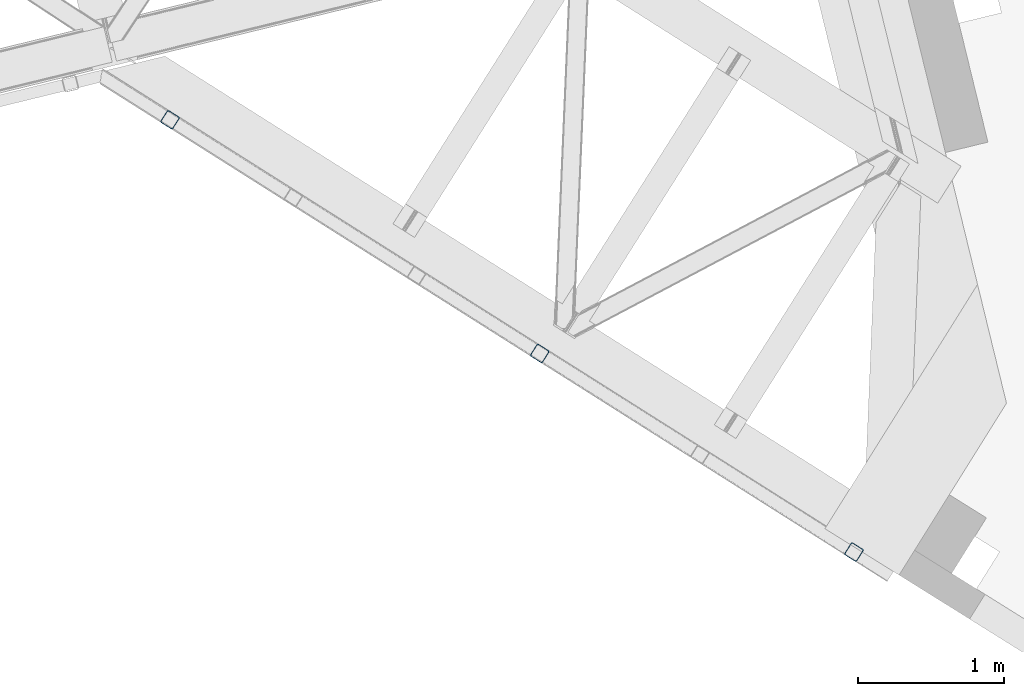
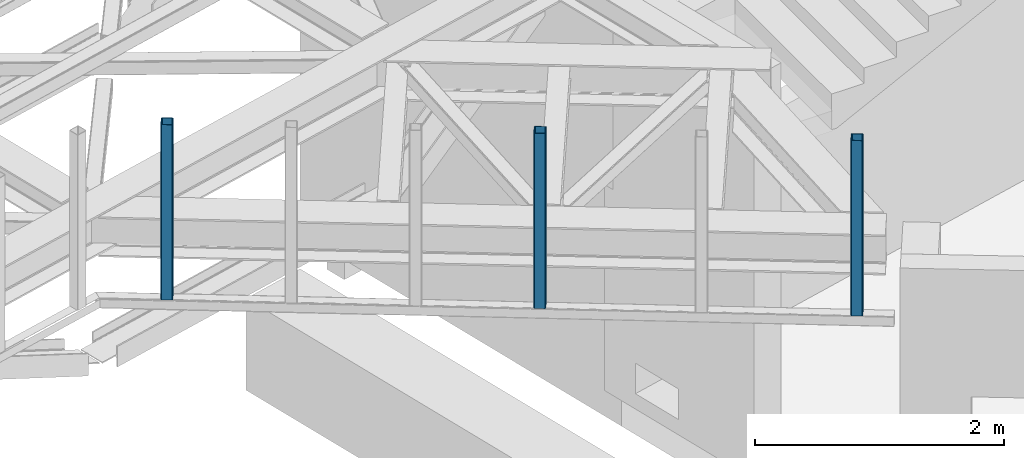
# One storey, part 9 of 66: 3 columns.
"""IFC4 building model written with IfcOpenShell, lengths in millimetres."""

from ifc_helpers import new_model, entity, si_unit, converted_unit, derived_unit, direction, frame, origin, place, context, subcontext, project, spatial, indexed_curve, outline, extrude, type_object, element, save


model = new_model("IFC4")

# Units and contexts
model_context = context("Model", 3, precision=0.01, world=origin(), true_north=direction((6.12303176911189e-17, 1.0)))
plan_context = context("Plan", 3, precision=0.01, world=origin(), true_north=direction((6.12303176911189e-17, 1.0)))
body_context = subcontext(model_context, "Body", "Model", "MODEL_VIEW")
ifc_project = project(units=[si_unit("LENGTHUNIT", "METRE", prefix="MILLI"), si_unit("AREAUNIT", "SQUARE_METRE"), si_unit("VOLUMEUNIT", "CUBIC_METRE"), converted_unit("PLANEANGLEUNIT", "DEGREE", entity("IfcRatioMeasure", 0.0174532925199433), si_unit("PLANEANGLEUNIT", "RADIAN"), dimensions=[0, 0, 0, 0, 0, 0, 0]), si_unit("MASSUNIT", "GRAM", prefix="KILO"), derived_unit("MASSDENSITYUNIT", [(si_unit("MASSUNIT", "GRAM", prefix="KILO"), 1), (si_unit("LENGTHUNIT", "METRE"), -3)]), derived_unit("MOMENTOFINERTIAUNIT", [(si_unit("LENGTHUNIT", "METRE"), 4)]), si_unit("TIMEUNIT", "SECOND"), si_unit("FREQUENCYUNIT", "HERTZ"), si_unit("THERMODYNAMICTEMPERATUREUNIT", "DEGREE_CELSIUS"), derived_unit("THERMALTRANSMITTANCEUNIT", [(si_unit("MASSUNIT", "GRAM", prefix="KILO"), 1), (si_unit("THERMODYNAMICTEMPERATUREUNIT", "KELVIN"), -1), (si_unit("TIMEUNIT", "SECOND"), -3)]), derived_unit("VOLUMETRICFLOWRATEUNIT", [(si_unit("LENGTHUNIT", "METRE"), 3), (si_unit("TIMEUNIT", "SECOND"), -1)]), derived_unit("MASSFLOWRATEUNIT", [(si_unit("MASSUNIT", "GRAM", prefix="KILO"), 1), (si_unit("TIMEUNIT", "SECOND"), -1)]), derived_unit("ROTATIONALFREQUENCYUNIT", [(si_unit("TIMEUNIT", "SECOND"), -1)]), si_unit("ELECTRICCURRENTUNIT", "AMPERE"), si_unit("ELECTRICVOLTAGEUNIT", "VOLT"), si_unit("POWERUNIT", "WATT"), si_unit("FORCEUNIT", "NEWTON", prefix="KILO"), si_unit("ILLUMINANCEUNIT", "LUX"), si_unit("LUMINOUSFLUXUNIT", "LUMEN"), si_unit("LUMINOUSINTENSITYUNIT", "CANDELA"), derived_unit("USERDEFINED", [(si_unit("MASSUNIT", "GRAM", prefix="KILO"), -1), (si_unit("LENGTHUNIT", "METRE"), -2), (si_unit("TIMEUNIT", "SECOND"), 3), (si_unit("LUMINOUSFLUXUNIT", "LUMEN"), 1)]), derived_unit("LINEARVELOCITYUNIT", [(si_unit("LENGTHUNIT", "METRE"), 1), (si_unit("TIMEUNIT", "SECOND"), -1)]), si_unit("PRESSUREUNIT", "PASCAL"), derived_unit("USERDEFINED", [(si_unit("LENGTHUNIT", "METRE"), -2), (si_unit("MASSUNIT", "GRAM", prefix="KILO"), 1), (si_unit("TIMEUNIT", "SECOND"), -2)]), derived_unit("LINEARFORCEUNIT", [(si_unit("MASSUNIT", "GRAM", prefix="KILO"), 1), (si_unit("LENGTHUNIT", "METRE"), 1), (si_unit("TIMEUNIT", "SECOND"), -2), (si_unit("LENGTHUNIT", "METRE"), -1)]), derived_unit("PLANARFORCEUNIT", [(si_unit("MASSUNIT", "GRAM", prefix="KILO"), 1), (si_unit("LENGTHUNIT", "METRE"), 1), (si_unit("TIMEUNIT", "SECOND"), -2), (si_unit("LENGTHUNIT", "METRE"), -2)])], contexts=[model_context, plan_context])

# Site, building, storey
site_placement = place(None, origin())
site = spatial("IfcSite", under=ifc_project, at=site_placement, CompositionType="ELEMENT")
building_placement = place(site_placement, origin())
building = spatial("IfcBuilding", under=site, at=building_placement, CompositionType="ELEMENT")
storey_placement = place(building_placement, frame((0.0, 0.0, 19800.0)))
storey = spatial("IfcBuildingStorey", under=building, at=storey_placement, Name="06", CompositionType="ELEMENT", Elevation=19800.0)

# Columns
column_type_1 = type_object("IfcColumnType", PredefinedType="COLUMN")
placement = place(storey_placement, origin())
element("IfcColumn", 1, at=placement, inside=storey, type_object=column_type_1, ObjectType="Steel Column", PredefinedType="COLUMN", context=body_context, shape_type="SweptSolid", body=[
    extrude(outline(indexed_curve([(29.4768951149887, -56.8428769007626), (33.3787015553205, -56.8428769007626), (36.9835006653681, -55.3497202197607), (39.7424944582164, -52.5907264269385), (41.2356511392555, -48.9859273169046), (56.8428769010712, 29.4768951152554), (56.842876901092, 33.3787015555708), (55.3497202201102, 36.9835006656042), (52.5907264272972, 39.7424944584316), (48.9859273172661, 41.2356511394393), (-29.4768951149897, 56.8428769007575), (-33.3787015553141, 56.8428769007627), (-36.9835006653618, 55.3497202197608), (-39.7424944582241, 52.5907264269286), (-41.2356511392497, 48.9859273169045), (-56.8428769010719, -29.4768951152604), (-56.8428769011011, -33.3787015555789), (-55.3497202201039, -36.983500665604), (-52.5907264272974, -39.7424944584386), (-48.9859273172602, -41.2356511394394), (29.4768951149887, -56.8428769007626)], self_intersect=False), holes=[indexed_curve([(-43.1065493051361, -37.3071763475209), (-46.711348415166, -35.8140196665104), (-49.4703422079919, -33.0550258736856), (-50.9634988889722, -29.4502267636517), (-50.9634988889409, -25.5484203233276), (-37.307176347356, 43.1065493048057), (-35.8140196663157, 46.7113484148424), (-33.0550258734699, 49.4703422076636), (-29.4502267634194, 50.9634988886596), (-25.5484203231011, 50.9634988886614), (43.1065493051387, 37.3071763475173), (46.7113484151633, 35.8140196665024), (49.4703422079667, 33.0550258736713), (50.9634988889637, 29.4502267636392), (50.9634988889363, 25.5484203233305), (37.3071763473442, -43.1065493048172), (35.8140196663094, -46.7113484148471), (33.0550258734735, -49.4703422076669), (29.4502267634084, -50.9634988886731), (25.5484203230805, -50.963498888674), (-43.1065493051361, -37.3071763475209)], self_intersect=False)]), frame((-2465.34, 14159.5, 3378.01), z_axis=(0.0, 0.0, 1.0), x_axis=(-0.933262879926923, 0.359194093702145, 0.0)), (0.0, 0.0, 1.0), 1720.0000000002),
])
column_type_2 = type_object("IfcColumnType", PredefinedType="COLUMN")
element("IfcColumn", 2, at=placement, inside=storey, type_object=column_type_2, ObjectType="Steel Column", PredefinedType="COLUMN", context=body_context, shape_type="SweptSolid", body=[
    extrude(outline(indexed_curve([(29.4768951150654, -56.8428769007209), (33.3787015553901, -56.8428769007209), (36.9835006654356, -55.3497202197144), (39.7424944582878, -52.5907264268834), (41.2356511393152, -48.9859273168526), (56.8428769010288, 29.4768951153275), (56.8428769010591, 33.3787015556532), (55.3497202200582, 36.9835006656744), (52.5907264272408, 39.7424944585002), (48.9859273172089, 41.2356511395014), (-29.4768951150681, 56.8428769007198), (-33.3787015553927, 56.8428769007198), (-36.9835006654375, 55.3497202197114), (-39.7424944582822, 52.5907264268856), (-41.2356511393169, 48.9859273168496), (-56.8428769010314, -29.4768951153285), (-56.8428769010475, -33.378701555644), (-55.3497202200599, -36.9835006656773), (-52.5907264272435, -39.7424944585012), (-48.9859273172105, -41.2356511395043), (29.4768951150654, -56.8428769007209)], self_intersect=False), holes=[indexed_curve([(-43.1065493050899, -37.307176347566), (-46.7113484151218, -35.8140196665695), (-49.4703422079311, -33.0550258737382), (-50.9634988889242, -29.4502267637071), (-50.9634988889087, -25.5484203233964), (-37.3071763473969, 43.1065493047724), (-35.8140196663806, 46.7113484147943), (-33.0550258735312, 49.4703422076219), (-29.4502267634749, 50.9634988886325), (-25.5484203231527, 50.9634988886292), (43.1065493050809, 37.3071763475603), (46.7113484151152, 35.8140196665623), (49.4703422079383, 33.0550258737433), (50.9634988889205, 29.4502267637149), (50.9634988889028, 25.5484203233918), (37.3071763474115, -43.1065493047505), (35.8140196663805, -46.7113484147943), (33.0550258735402, -49.4703422076207), (29.4502267634896, -50.9634988886338), (25.5484203231655, -50.9634988886336), (-43.1065493050899, -37.307176347566)], self_intersect=False)]), frame((-309.94, 12796.87, 3378.01), z_axis=(0.0, 0.0, 1.0), x_axis=(-0.933262879926458, 0.359194093703355, 0.0)), (0.0, 0.0, 1.0), 1720.0000000002),
])
column_type_3 = type_object("IfcColumnType", PredefinedType="COLUMN")
element("IfcColumn", 3, at=placement, inside=storey, type_object=column_type_3, ObjectType="Steel Column", PredefinedType="COLUMN", context=body_context, shape_type="SweptSolid", body=[
    extrude(outline(indexed_curve([(29.4768951149633, -56.8428769007716), (33.3787015552942, -56.8428769007716), (36.9835006653427, -55.3497202197717), (39.742494458185, -52.590726426956), (41.235651139218, -48.985927316926), (56.8428769010897, 29.4768951152342), (56.842876901112, 33.3787015555494), (55.3497202201253, 36.9835006655786), (52.590726427321, 39.7424944584125), (48.9859273172906, 41.2356511394221), (-29.4768951149575, 56.8428769007808), (-33.3787015552893, 56.8428769007828), (-36.983500665344, 55.3497202197781), (-39.7424944581937, 52.5907264269573), (-41.2356511392284, 48.9859273169289), (-56.8428769010847, -29.476895115223), (-56.8428769011151, -33.3787015555413), (-55.3497202201339, -36.9835006655773), (-52.590726427316, -39.7424944584013), (-48.9859273172857, -41.2356511394109), (29.4768951149633, -56.8428769007716)], self_intersect=False), holes=[indexed_curve([(-43.1065493051517, -37.3071763474948), (-46.7113484151879, -35.8140196664852), (-49.4703422080043, -33.0550258736559), (-50.9634988889827, -29.4502267636212), (-50.9634988889574, -25.5484203232956), (-37.3071763473315, 43.1065493048328), (-35.8140196662885, 46.7113484148667), (-33.05502587344, 49.4703422076847), (-29.4502267634012, 50.9634988886856), (-25.5484203230613, 50.9634988886774), (43.1065493051533, 37.3071763474815), (46.7113484151816, 35.8140196664804), (49.470342207997, 33.0550258736507), (50.9634988889759, 29.4502267636209), (50.9634988889449, 25.548420323307), (37.3071763473135, -43.1065493048281), (35.8140196662874, -46.7113484148579), (33.0550258734352, -49.4703422076842), (29.4502267633875, -50.9634988886862), (25.5484203230588, -50.963498888683), (-43.1065493051517, -37.3071763474948)], self_intersect=False)]), frame((-5001.1, 15762.59, 3378.01), z_axis=(0.0, 0.0, 1.0), x_axis=(-0.933262879927109, 0.359194093701662, 0.0)), (0.0, 0.0, 1.0), 1720.00000000022),
])

save(model, "model.ifc")
